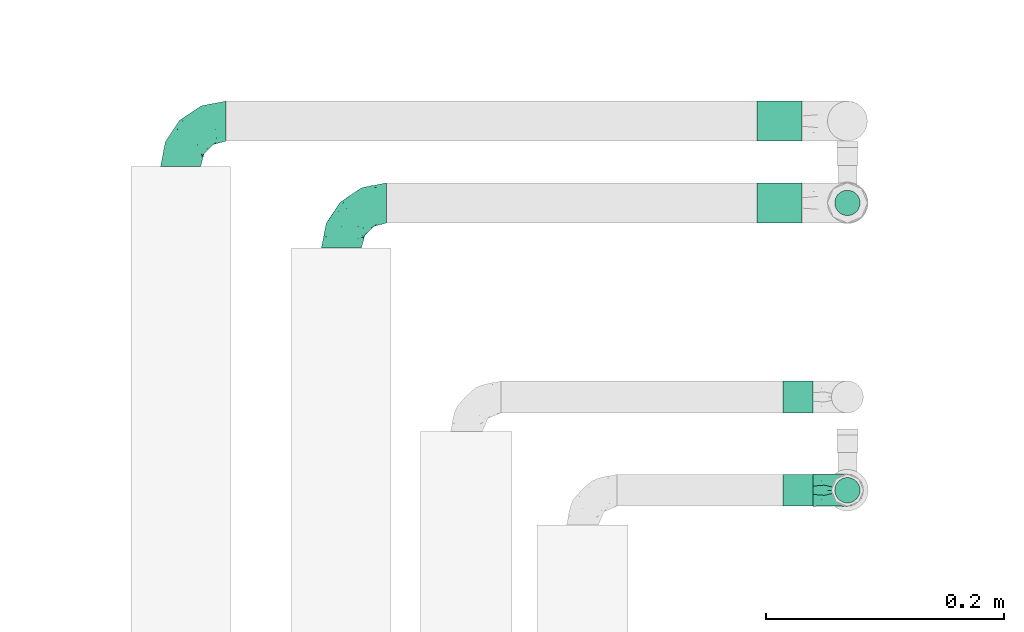
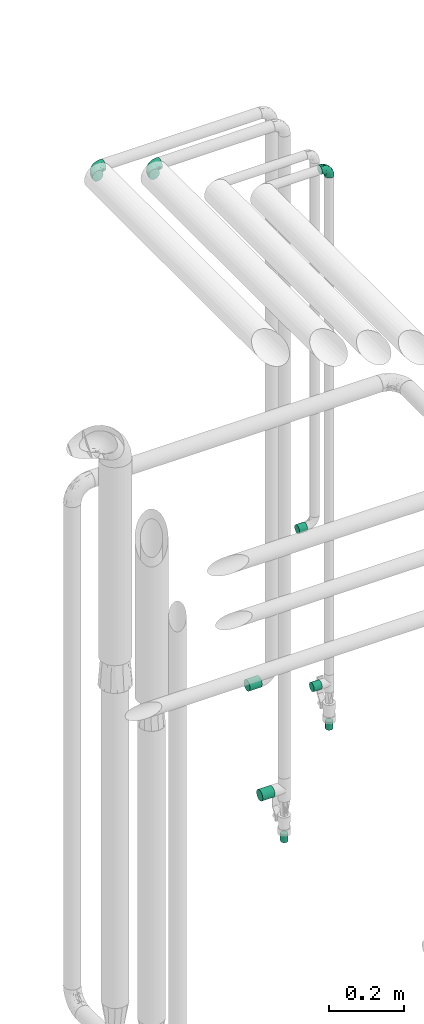
# One storey, part 743 of 824: 9 flow fittings.
"""IFC2X3 building model written with IfcOpenShell, lengths in millimetres."""

from ifc_helpers import new_model, entity, si_unit, converted_unit, derived_unit, direction, frame, origin, origin_2d_with_axis, place, context, subcontext, project, spatial, circle, extrude, faceted_brep, source, transform, mapped, material, type_object, type_shapes, element, save


model = new_model("IFC2X3")

# Units and contexts
model_context = context("Model", 3, precision=0.01, world=origin(), true_north=direction((6.12303176911189e-17, 1.0)))
body_context = subcontext(model_context, "Body", "Model", "MODEL_VIEW")
ifc_project = project(units=[si_unit("LENGTHUNIT", "METRE", prefix="MILLI"), si_unit("AREAUNIT", "SQUARE_METRE"), si_unit("VOLUMEUNIT", "CUBIC_METRE"), converted_unit("PLANEANGLEUNIT", "DEGREE", entity("IfcRatioMeasure", 0.0174532925199433), si_unit("PLANEANGLEUNIT", "RADIAN"), dimensions=[0, 0, 0, 0, 0, 0, 0]), si_unit("MASSUNIT", "GRAM", prefix="KILO"), derived_unit("MASSDENSITYUNIT", [(si_unit("MASSUNIT", "GRAM", prefix="KILO"), 1), (si_unit("LENGTHUNIT", "METRE"), -3)]), derived_unit("MOMENTOFINERTIAUNIT", [(si_unit("LENGTHUNIT", "METRE"), 4)]), si_unit("TIMEUNIT", "SECOND"), si_unit("FREQUENCYUNIT", "HERTZ"), si_unit("THERMODYNAMICTEMPERATUREUNIT", "DEGREE_CELSIUS"), derived_unit("THERMALTRANSMITTANCEUNIT", [(si_unit("MASSUNIT", "GRAM", prefix="KILO"), 1), (si_unit("THERMODYNAMICTEMPERATUREUNIT", "KELVIN"), -1), (si_unit("TIMEUNIT", "SECOND"), -3)]), derived_unit("VOLUMETRICFLOWRATEUNIT", [(si_unit("LENGTHUNIT", "METRE"), 3), (si_unit("TIMEUNIT", "SECOND"), -1)]), derived_unit("MASSFLOWRATEUNIT", [(si_unit("MASSUNIT", "GRAM", prefix="KILO"), 1), (si_unit("TIMEUNIT", "SECOND"), -1)]), derived_unit("ROTATIONALFREQUENCYUNIT", [(si_unit("TIMEUNIT", "SECOND"), -1)]), si_unit("ELECTRICCURRENTUNIT", "AMPERE"), si_unit("ELECTRICVOLTAGEUNIT", "VOLT"), si_unit("POWERUNIT", "WATT"), si_unit("FORCEUNIT", "NEWTON", prefix="KILO"), si_unit("ILLUMINANCEUNIT", "LUX"), si_unit("LUMINOUSFLUXUNIT", "LUMEN"), si_unit("LUMINOUSINTENSITYUNIT", "CANDELA"), derived_unit("USERDEFINED", [(si_unit("MASSUNIT", "GRAM", prefix="KILO"), -1), (si_unit("LENGTHUNIT", "METRE"), -2), (si_unit("TIMEUNIT", "SECOND"), 3), (si_unit("LUMINOUSFLUXUNIT", "LUMEN"), 1)]), derived_unit("LINEARVELOCITYUNIT", [(si_unit("LENGTHUNIT", "METRE"), 1), (si_unit("TIMEUNIT", "SECOND"), -1)]), si_unit("PRESSUREUNIT", "PASCAL"), derived_unit("USERDEFINED", [(si_unit("LENGTHUNIT", "METRE"), -2), (si_unit("MASSUNIT", "GRAM", prefix="KILO"), 1), (si_unit("TIMEUNIT", "SECOND"), -2)]), derived_unit("LINEARFORCEUNIT", [(si_unit("MASSUNIT", "GRAM", prefix="KILO"), 1), (si_unit("LENGTHUNIT", "METRE"), 1), (si_unit("TIMEUNIT", "SECOND"), -2), (si_unit("LENGTHUNIT", "METRE"), -1)]), derived_unit("PLANARFORCEUNIT", [(si_unit("MASSUNIT", "GRAM", prefix="KILO"), 1), (si_unit("LENGTHUNIT", "METRE"), 1), (si_unit("TIMEUNIT", "SECOND"), -2), (si_unit("LENGTHUNIT", "METRE"), -2)])], contexts=[model_context])

# Site, building, storey
site_placement = place(None, origin())
site = spatial("IfcSite", under=ifc_project, at=site_placement, CompositionType="ELEMENT")
building_placement = place(site_placement, origin())
building = spatial("IfcBuilding", under=site, at=building_placement, CompositionType="ELEMENT")
storey_placement = place(building_placement, frame((0.0, 0.0, 28200.0)))
storey = spatial("IfcBuildingStorey", under=building, at=storey_placement, CompositionType="ELEMENT", Elevation=28200.0)

# Flow fittings
ifc_material = material()
pipe_fitting_type_1 = type_object("IfcPipeFittingType", PredefinedType="NOTDEFINED", material=ifc_material)
shared_shape_1 = source(origin(), body_context, "Body", "SweptSolid", [
    extrude(circle(Radius=16.85, at=origin_2d_with_axis()), frame((0.0, 0.0, 0.0), z_axis=(1.0, 0.0, 0.0), x_axis=(0.0, 1.0, 0.0)), (0.0, 0.0, 1.0), 38.0000000000003),
])
type_shapes(pipe_fitting_type_1, [shared_shape_1])
for number, where, z_axis, x_axis in (
    (1, (18867.55, 16586.6, 738.03), (0.0, 1.0, 0.0), (-1.0, 0.0, 0.0)),
    (2, (18867.55, 16517.91, 419.5), (0.0, 1.0, 0.0), (-1.0, 0.0, 0.0)),
):
    element("IfcFlowFitting", number, at=place(storey_placement, frame(where, z_axis=z_axis, x_axis=x_axis)), inside=storey, type_object=pipe_fitting_type_1, material=ifc_material, context=body_context, shape_type="MappedRepresentation", body=[
        mapped(shared_shape_1, transform((0.0, 0.0, 0.0), scale=1.0)),
    ])
pipe_fitting_type_2 = type_object("IfcPipeFittingType", PredefinedType="NOTDEFINED", material=ifc_material)
shared_shape_2 = source(origin(), body_context, "Body", "SweptSolid", [
    extrude(circle(Radius=10.65, at=origin_2d_with_axis()), frame((0.0, 0.0, 0.0), z_axis=(1.0, 0.0, 0.0), x_axis=(0.0, 1.0, 0.0)), (0.0, 0.0, 1.0), 25.0000000000003),
])
type_shapes(pipe_fitting_type_2, [shared_shape_2])
for number, where, z_axis, x_axis in (
    (3, (18905.55, 16517.91, 269.5), (0.0, 1.0, 0.0), (0.0, 0.0, -1.0)),
    (4, (18905.55, 16276.57, 784.61), (0.0, 1.0, 0.0), (0.0, 0.0, -1.0)),
):
    element("IfcFlowFitting", number, at=place(storey_placement, frame(where, z_axis=z_axis, x_axis=x_axis)), inside=storey, type_object=pipe_fitting_type_2, material=ifc_material, context=body_context, shape_type="MappedRepresentation", body=[
        mapped(shared_shape_2, transform((0.0, 0.0, 0.0), scale=1.0)),
    ])
pipe_fitting_type_3 = type_object("IfcPipeFittingType", PredefinedType="NOTDEFINED", material=ifc_material)
shared_shape_3 = source(origin(), body_context, "Body", "SweptSolid", [
    extrude(circle(Radius=13.45, at=origin_2d_with_axis()), frame((0.0, 0.0, 0.0), z_axis=(1.0, 0.0, 0.0), x_axis=(0.0, 1.0, 0.0)), (0.0, 0.0, 1.0), 25.0000000000003),
])
type_shapes(pipe_fitting_type_3, [shared_shape_3])
for number, where, z_axis, x_axis in (
    (5, (18876.45, 16354.91, 1382.4), (0.0, 1.0, 0.0), (-1.0, 0.0, 0.0)),
    (6, (18876.55, 16276.57, 912.61), (0.0, 1.0, 0.0), (-1.0, 0.0, 0.0)),
):
    element("IfcFlowFitting", number, at=place(storey_placement, frame(where, z_axis=z_axis, x_axis=x_axis)), inside=storey, type_object=pipe_fitting_type_3, material=ifc_material, context=body_context, shape_type="MappedRepresentation", body=[
        mapped(shared_shape_3, transform((0.0, 0.0, 0.0), scale=1.0)),
    ])
pipe_fitting_type_4 = type_object("IfcPipeFittingType", PredefinedType="NOTDEFINED", material=ifc_material)
shared_shape_4 = source(origin(), body_context, "Body", "Brep", [
    faceted_brep([(-38.0, 0.0, -16.85), (-38.0, -4.36, -16.28), (-38.0, -8.43, -14.59), (-38.0, -11.91, -11.91), (-38.0, -14.59, -8.43), (-38.0, -16.28, -4.36), (-38.0, -16.85, 0.0), (-38.0, -16.28, 4.36), (-38.0, -14.59, 8.42), (-38.0, -11.91, 11.91), (-38.0, -8.43, 14.59), (-38.0, -4.36, 16.28), (-38.0, 0.0, 16.85), (-38.0, 4.36, 16.28), (-38.0, 8.42, 14.59), (-38.0, 11.91, 11.91), (-38.0, 14.59, 8.42), (-38.0, 16.28, 4.36), (-38.0, 16.85, 0.0), (-38.0, 16.28, -4.36), (-38.0, 14.59, -8.43), (-38.0, 11.91, -11.91), (-38.0, 8.42, -14.59), (-38.0, 4.36, -16.28), (-4.36, 38.0, -16.28), (-8.42, 38.0, -14.59), (-11.91, 38.0, -11.91), (-14.59, 38.0, -8.43), (-16.28, 38.0, -4.36), (-16.85, 38.0, 0.0), (-16.28, 38.0, 4.36), (-14.59, 38.0, 8.42), (-11.91, 38.0, 11.91), (-8.42, 38.0, 14.59), (-4.36, 38.0, 16.28), (0.0, 38.0, 16.85), (4.36, 38.0, 16.28), (8.43, 38.0, 14.59), (11.91, 38.0, 11.91), (14.59, 38.0, 8.42), (16.28, 38.0, 4.36), (16.85, 38.0, 0.0), (16.28, 38.0, -4.36), (14.59, 38.0, -8.43), (11.91, 38.0, -11.91), (8.43, 38.0, -14.59), (4.36, 38.0, -16.28), (0.0, 38.0, -16.85), (-27.9, -12.9, 9.54), (-27.5, -14.76, 0.0), (-16.53, -9.86, 8.66), (-24.93, -9.38, 12.63), (-29.29, -2.05, 16.58), (-26.82, 2.86, 16.81), (-25.18, -14.43, 5.37), (-4.54, 4.54, 14.04), (-15.36, -3.29, 14.19), (-7.56, -2.74, 10.9), (-28.06, -6.15, 15.21), (9.38, 24.93, 12.63), (-4.71, -4.42, 5.51), (-14.62, -10.99, 4.34), (-8.11, -6.73, 0.0), (-19.46, 0.42, 16.39), (-29.52, 14.25, 10.97), (-26.45, 18.14, 7.62), (-32.84, 15.94, 6.96), (-23.39, 16.22, 12.05), (-11.89, 8.53, 16.79), (-5.59, 13.42, 16.64), (-6.64, 18.62, 16.81), (-32.37, 10.35, 13.72), (-6.4, 32.67, 15.76), (-2.55, 28.48, 16.8), (6.81, 15.56, 11.71), (3.29, 15.36, 14.19), (-29.89, 18.0, 3.79), (-29.34, 6.81, 15.88), (-10.26, 4.27, 15.87), (-2.97, 11.0, 15.66), (2.45, 6.84, 10.65), (-1.8, -0.14, 8.44), (5.0, 5.5, 5.57), (-17.68, 27.4, 7.52), (14.43, 25.18, 5.37), (12.9, 27.9, 9.54), (9.86, 16.53, 8.66), (6.15, 28.06, 15.21), (-17.01, -12.67, 0.0), (2.05, 29.29, 16.58), (14.76, 27.5, 0.0), (10.99, 14.62, 4.34), (12.67, 17.01, 0.0), (-15.84, -6.82, 11.83), (-7.71, 25.61, 16.01), (-22.69, 22.69, 4.1), (-19.68, 27.42, 0.0), (-27.42, 19.68, 0.0), (-18.11, 29.67, 3.72), (-10.87, 29.33, 13.9), (-20.83, 21.64, 8.95), (-18.54, 20.86, 11.76), (-14.08, 30.19, 10.92), (-13.69, 20.27, 14.88), (-20.85, 7.92, 16.51), (-19.04, 4.79, 16.85), (-19.82, 12.26, 15.55), (-19.27, 16.43, 13.96), (-10.72, 19.56, 16.07), (-0.42, 19.46, 16.39), (-25.32, 12.08, 14.15), (-9.04, -6.0, 8.28), (-13.94, 13.94, 16.38), (0.78, -0.78, 0.0), (6.73, 8.11, 0.0), (-9.04, -6.0, -8.28), (-15.9, -7.04, -11.65), (-7.56, -2.74, -10.9), (6.15, 28.06, -15.21), (3.29, 15.36, -14.19), (-0.42, 19.46, -16.39), (-30.19, 14.08, -10.92), (-29.33, 10.87, -13.9), (-25.61, 7.71, -16.01), (-32.67, 6.4, -15.76), (-29.67, 18.11, -3.72), (-18.14, 26.45, -7.62), (-22.69, 22.69, -4.1), (-18.0, 29.89, -3.79), (-25.18, -14.43, -5.37), (-14.62, -10.99, -4.34), (-20.27, 13.69, -14.88), (-15.36, -3.29, -14.19), (-14.25, 29.52, -10.97), (-15.94, 32.84, -6.96), (-24.93, -9.38, -12.63), (-27.9, -12.9, -9.54), (6.81, 15.56, -11.71), (9.38, 24.93, -12.63), (-7.92, 20.85, -16.51), (-4.79, 19.04, -16.85), (-8.53, 11.89, -16.79), (-29.29, -2.05, -16.58), (-13.42, 5.59, -16.64), (-4.27, 10.26, -15.87), (-11.0, 2.97, -15.66), (-16.53, -9.86, -8.66), (-28.48, 2.55, -16.8), (-18.62, 6.64, -16.81), (10.99, 14.62, -4.34), (14.43, 25.18, -5.37), (-12.26, 19.82, -15.55), (-16.43, 19.27, -13.96), (12.9, 27.9, -9.54), (-10.35, 32.37, -13.72), (-6.81, 29.34, -15.88), (2.05, 29.29, -16.58), (-2.86, 26.82, -16.81), (-27.4, 17.68, -7.52), (5.0, 5.5, -5.57), (-16.22, 23.39, -12.05), (-28.06, -6.15, -15.21), (9.86, 16.53, -8.66), (-20.86, 18.54, -11.76), (-21.64, 20.83, -8.95), (-19.56, 10.72, -16.07), (-19.46, 0.42, -16.39), (-12.08, 25.32, -14.15), (-4.54, 4.54, -14.04), (-13.94, 13.94, -16.38), (2.45, 6.84, -10.65), (-4.71, -4.42, -5.51), (-1.8, -0.14, -8.44)], [[[0, 1, 2, 3, 4, 5, 6, 7, 8, 9, 10, 11, 12, 13, 14, 15, 16, 17, 18, 19, 20, 21, 22, 23]], [[24, 25, 26, 27, 28, 29, 30, 31, 32, 33, 34, 35, 36, 37, 38, 39, 40, 41, 42, 43, 44, 45, 46, 47]], [[8, 48, 9]], [[7, 6, 49]], [[48, 50, 51]], [[12, 52, 53]], [[8, 54, 48]], [[7, 54, 8]], [[55, 56, 57]], [[51, 10, 9]], [[51, 58, 10]], [[59, 38, 37]], [[60, 61, 62]], [[58, 56, 63]], [[64, 65, 66]], [[67, 65, 64]], [[68, 69, 70]], [[14, 71, 15]], [[11, 52, 12]], [[34, 72, 73]], [[12, 53, 13]], [[15, 64, 16]], [[74, 59, 75]], [[18, 17, 76]], [[66, 17, 16]], [[77, 13, 53]], [[13, 77, 14]], [[69, 78, 79]], [[80, 81, 82]], [[31, 30, 83]], [[84, 85, 86]], [[59, 87, 75]], [[61, 54, 88]], [[35, 89, 36]], [[84, 40, 39]], [[35, 34, 73]], [[90, 40, 84]], [[39, 38, 85]], [[10, 58, 11]], [[85, 84, 39]], [[91, 84, 86]], [[84, 92, 90]], [[87, 37, 36]], [[93, 56, 51]], [[94, 70, 73]], [[95, 96, 97]], [[84, 91, 92]], [[96, 98, 29]], [[33, 32, 99]], [[76, 95, 97]], [[100, 101, 83]], [[102, 99, 32]], [[65, 95, 76]], [[103, 94, 99]], [[95, 98, 96]], [[72, 99, 94]], [[72, 34, 33]], [[101, 99, 102]], [[7, 49, 54]], [[87, 59, 37]], [[104, 105, 68]], [[106, 103, 107]], [[106, 77, 104]], [[32, 31, 102]], [[94, 103, 108]], [[94, 108, 70]], [[89, 73, 109]], [[71, 64, 15]], [[110, 107, 67]], [[50, 48, 54]], [[51, 9, 48]], [[56, 58, 51]], [[88, 54, 49]], [[52, 58, 63]], [[50, 111, 93]], [[56, 55, 78]], [[38, 59, 85]], [[86, 85, 59]], [[89, 87, 36]], [[41, 40, 90]], [[109, 79, 75]], [[109, 75, 87]], [[75, 55, 80]], [[104, 77, 53]], [[71, 77, 110]], [[31, 83, 102]], [[101, 102, 83]], [[99, 101, 103]], [[106, 107, 110]], [[68, 70, 112]], [[109, 73, 70]], [[68, 112, 104]], [[68, 63, 78]], [[57, 93, 111]], [[80, 55, 57]], [[61, 50, 54]], [[80, 82, 86]], [[81, 57, 111]], [[74, 86, 59]], [[60, 113, 82]], [[82, 114, 91]], [[100, 95, 65]], [[98, 95, 83]], [[73, 89, 35]], [[87, 89, 109]], [[58, 52, 11]], [[53, 52, 63]], [[104, 53, 105]], [[106, 104, 112]], [[18, 76, 97]], [[76, 17, 66]], [[103, 106, 112]], [[77, 106, 110]], [[103, 101, 107]], [[67, 107, 101]], [[67, 101, 100]], [[110, 67, 64]], [[83, 30, 98]], [[29, 98, 30]], [[53, 63, 105]], [[63, 68, 105]], [[56, 78, 63]], [[79, 78, 55]], [[75, 79, 55]], [[69, 79, 109]], [[70, 69, 109]], [[78, 69, 68]], [[62, 113, 60]], [[111, 61, 60]], [[61, 88, 62]], [[86, 82, 91]], [[77, 71, 14]], [[114, 82, 113]], [[114, 92, 91]], [[64, 71, 110]], [[99, 72, 33]], [[73, 72, 94]], [[64, 66, 16]], [[76, 66, 65]], [[95, 100, 83]], [[67, 100, 65]], [[75, 80, 74]], [[80, 86, 74]], [[103, 112, 108]], [[70, 108, 112]], [[50, 93, 51]], [[57, 56, 93]], [[61, 111, 50]], [[81, 111, 60]], [[82, 81, 60]], [[80, 57, 81]], [[115, 116, 117]], [[118, 119, 120]], [[121, 122, 21]], [[123, 124, 122]], [[97, 125, 18]], [[126, 127, 128]], [[127, 97, 96]], [[129, 130, 88]], [[123, 122, 131]], [[116, 132, 117]], [[133, 126, 134]], [[22, 124, 23]], [[3, 135, 136]], [[137, 119, 138]], [[129, 88, 49]], [[139, 140, 141]], [[4, 3, 136]], [[45, 118, 46]], [[142, 1, 0]], [[143, 144, 145]], [[4, 129, 5]], [[129, 136, 146]], [[147, 0, 23]], [[22, 21, 122]], [[127, 125, 97]], [[123, 148, 147]], [[96, 128, 127]], [[149, 150, 92]], [[29, 28, 128]], [[151, 131, 152]], [[26, 133, 27]], [[153, 44, 43]], [[135, 3, 2]], [[26, 25, 154]], [[155, 25, 24]], [[47, 156, 157]], [[47, 46, 156]], [[20, 19, 158]], [[159, 149, 114]], [[126, 133, 160]], [[141, 143, 148]], [[45, 138, 118]], [[161, 135, 2]], [[155, 24, 157]], [[23, 124, 147]], [[115, 146, 116]], [[44, 153, 138]], [[138, 45, 44]], [[153, 162, 138]], [[161, 2, 1]], [[41, 90, 42]], [[130, 129, 146]], [[49, 5, 129]], [[42, 150, 43]], [[163, 122, 121]], [[47, 157, 24]], [[135, 161, 132]], [[134, 28, 27]], [[42, 90, 150]], [[164, 163, 158]], [[151, 155, 139]], [[21, 20, 121]], [[123, 131, 165]], [[123, 165, 148]], [[142, 147, 166]], [[154, 133, 26]], [[167, 152, 160]], [[146, 136, 135]], [[6, 5, 49]], [[129, 4, 136]], [[142, 161, 1]], [[166, 145, 132]], [[166, 132, 161]], [[132, 168, 117]], [[43, 150, 153]], [[92, 150, 90]], [[162, 153, 150]], [[119, 118, 138]], [[156, 118, 120]], [[137, 138, 162]], [[119, 168, 144]], [[139, 155, 157]], [[154, 155, 167]], [[20, 158, 121]], [[163, 121, 158]], [[122, 163, 131]], [[151, 152, 167]], [[141, 148, 169]], [[166, 147, 148]], [[141, 169, 139]], [[141, 120, 144]], [[168, 170, 117]], [[159, 171, 172]], [[115, 172, 171]], [[171, 62, 130]], [[119, 170, 168]], [[170, 162, 159]], [[149, 162, 150]], [[113, 171, 159]], [[164, 127, 126]], [[125, 127, 158]], [[147, 142, 0]], [[161, 142, 166]], [[118, 156, 46]], [[157, 156, 120]], [[139, 157, 140]], [[151, 139, 169]], [[29, 128, 96]], [[128, 28, 134]], [[131, 151, 169]], [[155, 151, 167]], [[131, 163, 152]], [[160, 152, 163]], [[160, 163, 164]], [[167, 160, 133]], [[158, 19, 125]], [[18, 125, 19]], [[157, 120, 140]], [[120, 141, 140]], [[119, 144, 120]], [[145, 144, 168]], [[132, 145, 168]], [[143, 145, 166]], [[148, 143, 166]], [[144, 143, 141]], [[115, 130, 146]], [[114, 113, 159]], [[62, 171, 113]], [[62, 88, 130]], [[159, 162, 149]], [[149, 92, 114]], [[155, 154, 25]], [[133, 154, 167]], [[122, 124, 22]], [[147, 124, 123]], [[133, 134, 27]], [[128, 134, 126]], [[127, 164, 158]], [[160, 164, 126]], [[162, 170, 137]], [[170, 119, 137]], [[131, 169, 165]], [[148, 165, 169]], [[146, 135, 116]], [[132, 116, 135]], [[172, 115, 117]], [[130, 115, 171]], [[117, 170, 172]], [[159, 172, 170]]]),
])
type_shapes(pipe_fitting_type_4, [shared_shape_4])
for number, where, z_axis, x_axis in (
    (7, (18480.55, 16517.91, 2600.0), (0.0, 0.0, 1.0), (-1.0, 0.0, 0.0)),
    (8, (18345.55, 16586.6, 2600.0), (0.0, 0.0, 1.0), (-1.0, 0.0, 0.0)),
):
    element("IfcFlowFitting", number, at=place(storey_placement, frame(where, z_axis=z_axis, x_axis=x_axis)), inside=storey, type_object=pipe_fitting_type_4, material=ifc_material, context=body_context, shape_type="MappedRepresentation", body=[
        mapped(shared_shape_4, transform((0.0, 0.0, 0.0), scale=1.0)),
    ])
pipe_fitting_type_5 = type_object("IfcPipeFittingType", PredefinedType="NOTDEFINED", material=ifc_material)
shared_shape_5 = source(origin(), body_context, "Body", "Brep", [
    faceted_brep([(-29.1, 0.0, -13.45), (-29.1, -3.48, -12.99), (-29.1, -6.73, -11.65), (-29.1, -9.51, -9.51), (-29.1, -11.65, -6.73), (-29.1, -12.99, -3.48), (-29.1, -13.45, 0.0), (-29.1, -12.99, 3.48), (-29.1, -11.65, 6.72), (-29.1, -9.51, 9.51), (-29.1, -6.73, 11.65), (-29.1, -3.48, 12.99), (-29.1, 0.0, 13.45), (-29.1, 3.48, 12.99), (-29.1, 6.72, 11.65), (-29.1, 9.51, 9.51), (-29.1, 11.65, 6.72), (-29.1, 12.99, 3.48), (-29.1, 13.45, 0.0), (-29.1, 12.99, -3.48), (-29.1, 11.65, -6.73), (-29.1, 9.51, -9.51), (-29.1, 6.72, -11.65), (-29.1, 3.48, -12.99), (-3.48, 29.1, -12.99), (-6.72, 29.1, -11.65), (-9.51, 29.1, -9.51), (-11.65, 29.1, -6.73), (-12.99, 29.1, -3.48), (-13.45, 29.1, 0.0), (-12.99, 29.1, 3.48), (-11.65, 29.1, 6.72), (-9.51, 29.1, 9.51), (-6.72, 29.1, 11.65), (-3.48, 29.1, 12.99), (0.0, 29.1, 13.45), (3.48, 29.1, 12.99), (6.73, 29.1, 11.65), (9.51, 29.1, 9.51), (11.65, 29.1, 6.72), (12.99, 29.1, 3.48), (13.45, 29.1, 0.0), (12.99, 29.1, -3.48), (11.65, 29.1, -6.73), (9.51, 29.1, -9.51), (6.73, 29.1, -11.65), (3.48, 29.1, -12.99), (0.0, 29.1, -13.45), (-19.62, -11.66, 4.28), (-21.41, -10.36, 7.6), (-16.26, -10.01, 0.0), (-12.48, -9.76, 2.75), (-10.66, 15.6, 11.91), (-15.27, 9.55, 12.42), (-10.71, 10.71, 13.09), (-0.04, 0.04, 0.0), (0.49, -0.45, 4.38), (-3.67, -4.15, 4.26), (-22.68, -11.73, 0.0), (-21.45, -4.97, 12.13), (-11.59, -2.84, 11.28), (-14.77, 0.17, 13.07), (-19.08, -7.58, 10.06), (-22.36, -1.69, 13.23), (-20.49, 2.21, 13.42), (-7.82, -7.75, 0.0), (-5.53, -2.55, 8.58), (-1.33, -0.87, 6.53), (-1.15, 1.15, 8.49), (-22.46, 5.38, 12.69), (-14.04, 21.05, 6.04), (-3.19, 3.19, 11.14), (-5.08, 25.05, 12.59), (-1.97, 21.79, 13.41), (-22.68, 11.31, 8.78), (-18.16, 12.64, 9.68), (-20.46, 14.33, 6.11), (-4.13, 10.11, 13.26), (-7.66, 3.08, 12.63), (-2.02, 8.24, 12.45), (-24.91, 8.22, 10.95), (-5.08, 14.28, 13.42), (-8.96, 6.48, 13.4), (-19.7, 16.14, 3.1), (-18.03, 18.03, 0.0), (-23.05, 15.96, 0.0), (-25.26, 12.69, 5.56), (4.97, 21.45, 12.13), (7.58, 19.08, 10.06), (1.69, 22.36, 13.23), (10.36, 21.41, 7.6), (8.11, 12.69, 6.86), (11.66, 19.62, 4.28), (-6.03, 19.65, 12.79), (9.76, 12.48, 2.75), (10.01, 16.26, 0.0), (-14.58, 16.06, 9.44), (-11.19, 23.14, 8.74), (-16.29, 16.8, 7.24), (-11.99, -5.68, 9.36), (-15.42, 20.78, 3.08), (5.79, 12.02, 9.27), (2.84, 11.59, 11.28), (2.55, 5.53, 8.58), (-15.74, 23.57, 0.0), (-15.96, 23.05, 0.0), (-24.62, 13.88, 2.39), (-8.61, 22.49, 11.12), (-14.98, 12.8, 11.14), (11.73, 22.68, 0.0), (-12.69, -8.11, 6.86), (7.75, 7.82, 0.0), (-15.98, 6.12, 13.19), (-14.48, 3.64, 13.45), (-19.6, 9.46, 11.31), (-8.3, 15.02, 12.85), (-0.17, 14.77, 13.07), (-6.9, -5.2, 6.52), (7.5, 8.93, 4.46), (5.22, 6.95, 6.56), (-8.85, -7.47, 4.42), (3.86, 3.93, 0.0), (4.18, 3.75, 4.31), (-23.57, 15.74, 0.0), (-3.93, -3.86, 0.0), (-21.79, 1.97, -13.41), (-11.31, 22.68, -8.78), (-14.33, 20.46, -6.11), (-12.69, 25.26, -5.56), (4.97, 21.45, -12.13), (2.84, 11.59, -11.28), (-0.17, 14.77, -13.07), (-25.05, 5.08, -12.59), (-16.8, 16.29, -7.24), (-20.78, 15.42, -3.08), (-16.14, 19.7, -3.1), (-12.02, -5.79, -9.27), (-11.59, -2.84, -11.28), (-5.53, -2.55, -8.58), (-23.14, 11.19, -8.74), (-22.49, 8.61, -11.12), (-1.33, -0.87, -6.53), (-3.67, -4.15, -4.26), (-6.9, -5.2, -6.52), (-19.65, 6.03, -12.79), (-15.6, 10.66, -11.91), (-14.28, 5.08, -13.42), (-10.71, 10.71, -13.09), (-6.48, 8.96, -13.4), (-19.62, -11.66, -4.28), (-21.41, -10.36, -7.6), (-12.48, -9.76, -2.75), (11.66, 19.62, -4.28), (-12.69, -8.11, -6.86), (-22.36, -1.69, -13.23), (-16.06, 14.58, -9.44), (5.68, 11.99, -9.36), (7.58, 19.08, -10.06), (-19.08, -7.58, -10.06), (-21.45, -4.97, -12.13), (-9.55, 15.27, -12.42), (-12.8, 14.98, -11.14), (-8.22, 24.91, -10.95), (10.36, 21.41, -7.6), (-5.38, 22.46, -12.69), (1.69, 22.36, -13.23), (-2.21, 20.49, -13.42), (-12.64, 18.16, -9.68), (-21.05, 14.04, -6.04), (9.76, 12.48, -2.75), (-10.11, 4.13, -13.26), (-3.08, 7.66, -12.63), (-8.24, 2.02, -12.45), (-13.88, 24.62, -2.39), (8.11, 12.69, -6.86), (-6.12, 15.98, -13.19), (-3.64, 14.48, -13.45), (-9.46, 19.6, -11.31), (-15.02, 8.3, -12.85), (-14.77, 0.17, -13.07), (-3.19, 3.19, -11.14), (5.22, 6.95, -6.56), (2.55, 5.53, -8.58), (0.49, -0.45, -4.38), (4.18, 3.75, -4.31), (-8.85, -7.47, -4.42), (-1.15, 1.15, -8.49), (7.5, 8.93, -4.46)], [[[0, 1, 2, 3, 4, 5, 6, 7, 8, 9, 10, 11, 12, 13, 14, 15, 16, 17, 18, 19, 20, 21, 22, 23]], [[24, 25, 26, 27, 28, 29, 30, 31, 32, 33, 34, 35, 36, 37, 38, 39, 40, 41, 42, 43, 44, 45, 46, 47]], [[48, 49, 8]], [[48, 50, 51]], [[52, 53, 54]], [[55, 56, 57]], [[49, 9, 8]], [[58, 48, 7]], [[59, 60, 61]], [[62, 10, 9]], [[62, 59, 10]], [[12, 63, 64]], [[51, 50, 65]], [[66, 67, 68]], [[12, 11, 63]], [[69, 14, 13]], [[31, 30, 70]], [[66, 71, 60]], [[34, 72, 73]], [[74, 75, 76]], [[77, 78, 79]], [[14, 80, 15]], [[16, 15, 74]], [[81, 54, 82]], [[83, 84, 85]], [[74, 76, 86]], [[37, 87, 88]], [[88, 38, 37]], [[36, 35, 89]], [[90, 91, 92]], [[93, 81, 73]], [[35, 34, 73]], [[10, 59, 11]], [[92, 94, 95]], [[96, 97, 98]], [[90, 92, 39]], [[99, 60, 62]], [[40, 39, 92]], [[87, 37, 36]], [[100, 84, 83]], [[50, 48, 58]], [[100, 83, 98]], [[101, 102, 103]], [[104, 105, 84, 100, 29]], [[48, 8, 7]], [[86, 17, 16]], [[106, 18, 17]], [[32, 97, 107]], [[53, 52, 108]], [[52, 93, 107]], [[97, 96, 107]], [[72, 107, 93]], [[72, 34, 33]], [[92, 109, 40]], [[33, 32, 107]], [[69, 13, 64]], [[88, 87, 102]], [[12, 64, 13]], [[49, 110, 62]], [[39, 38, 90]], [[95, 94, 111]], [[112, 113, 82]], [[53, 69, 112]], [[80, 74, 15]], [[114, 108, 75]], [[32, 31, 97]], [[115, 52, 54]], [[93, 115, 81]], [[89, 73, 116]], [[106, 76, 83]], [[106, 83, 85]], [[83, 76, 98]], [[100, 30, 29]], [[60, 59, 62]], [[63, 59, 61]], [[110, 117, 99]], [[60, 71, 78]], [[89, 87, 36]], [[116, 79, 102]], [[116, 102, 87]], [[102, 71, 103]], [[110, 49, 48]], [[62, 9, 49]], [[38, 88, 90]], [[91, 90, 88]], [[112, 69, 64]], [[80, 69, 114]], [[111, 94, 118]], [[119, 101, 103]], [[117, 66, 99]], [[117, 120, 57]], [[119, 91, 101]], [[66, 68, 71]], [[66, 117, 67]], [[121, 111, 122, 55]], [[56, 55, 122]], [[31, 70, 97]], [[97, 70, 98]], [[107, 96, 52]], [[53, 108, 114]], [[112, 82, 54]], [[116, 73, 81]], [[78, 82, 61]], [[81, 82, 77]], [[73, 89, 35]], [[87, 89, 116]], [[59, 63, 11]], [[64, 63, 61]], [[112, 64, 113]], [[53, 112, 54]], [[7, 6, 58]], [[109, 92, 95]], [[109, 41, 40]], [[69, 53, 114]], [[52, 96, 108]], [[75, 108, 96]], [[75, 96, 98]], [[114, 75, 74]], [[64, 61, 113]], [[61, 82, 113]], [[91, 88, 101]], [[110, 48, 51]], [[92, 91, 94]], [[91, 119, 118]], [[106, 85, 123, 18]], [[106, 17, 86]], [[60, 78, 61]], [[79, 78, 71]], [[102, 79, 71]], [[77, 79, 116]], [[81, 77, 116]], [[78, 77, 82]], [[69, 80, 14]], [[74, 80, 114]], [[74, 86, 16]], [[106, 86, 76]], [[107, 72, 33]], [[73, 72, 93]], [[98, 70, 100]], [[75, 98, 76]], [[30, 100, 70]], [[110, 99, 62]], [[66, 60, 99]], [[120, 110, 51]], [[67, 117, 57]], [[57, 56, 67]], [[67, 122, 119]], [[110, 120, 117]], [[65, 120, 51]], [[57, 65, 124, 55]], [[122, 67, 56]], [[67, 103, 68]], [[71, 68, 103]], [[65, 57, 120]], [[102, 101, 88]], [[67, 119, 103]], [[118, 119, 122]], [[118, 122, 111]], [[91, 118, 94]], [[81, 115, 54]], [[93, 52, 115]], [[23, 125, 0]], [[126, 127, 128]], [[129, 130, 131]], [[23, 22, 132]], [[133, 134, 135]], [[136, 137, 138]], [[21, 139, 140]], [[141, 142, 143]], [[144, 140, 145]], [[143, 136, 138]], [[146, 147, 148]], [[144, 132, 140]], [[5, 4, 149]], [[4, 3, 150]], [[45, 129, 46]], [[151, 50, 149]], [[152, 43, 42]], [[42, 41, 109]], [[150, 149, 4]], [[153, 149, 150]], [[154, 1, 0]], [[139, 155, 140]], [[156, 130, 157]], [[149, 58, 5]], [[18, 123, 85, 84, 134]], [[158, 159, 137]], [[84, 105, 135]], [[160, 145, 161]], [[143, 153, 136]], [[27, 26, 126]], [[25, 162, 26]], [[152, 163, 43]], [[25, 24, 164]], [[47, 165, 166]], [[158, 3, 2]], [[167, 127, 126]], [[20, 19, 168]], [[47, 46, 165]], [[44, 157, 45]], [[23, 132, 125]], [[44, 43, 163]], [[158, 2, 159]], [[47, 166, 24]], [[129, 45, 157]], [[164, 24, 166]], [[134, 84, 135]], [[95, 169, 152]], [[22, 21, 140]], [[144, 146, 125]], [[109, 152, 42]], [[95, 152, 109]], [[170, 171, 172]], [[155, 139, 133]], [[28, 27, 128]], [[159, 2, 1]], [[173, 29, 28]], [[50, 151, 65]], [[169, 95, 111]], [[163, 174, 157]], [[175, 176, 148]], [[160, 164, 175]], [[162, 126, 26]], [[177, 161, 167]], [[21, 20, 139]], [[144, 145, 178]], [[144, 178, 146]], [[154, 125, 179]], [[173, 127, 135]], [[173, 135, 105]], [[135, 127, 133]], [[134, 19, 18]], [[154, 159, 1]], [[179, 172, 137]], [[179, 137, 159]], [[137, 180, 138]], [[130, 129, 157]], [[165, 129, 131]], [[174, 181, 156]], [[130, 180, 171]], [[3, 158, 150]], [[153, 150, 158]], [[174, 163, 152]], [[157, 44, 163]], [[175, 164, 166]], [[162, 164, 177]], [[130, 182, 180]], [[181, 141, 182]], [[55, 183, 184]], [[65, 151, 185]], [[183, 55, 142]], [[156, 181, 182]], [[180, 182, 186]], [[181, 187, 184]], [[65, 142, 55, 124]], [[20, 168, 139]], [[139, 168, 133]], [[140, 155, 145]], [[160, 161, 177]], [[175, 148, 147]], [[179, 125, 146]], [[171, 148, 131]], [[146, 148, 170]], [[125, 154, 0]], [[159, 154, 179]], [[129, 165, 46]], [[166, 165, 131]], [[175, 166, 176]], [[160, 175, 147]], [[58, 149, 50]], [[58, 6, 5]], [[145, 160, 147]], [[164, 160, 177]], [[145, 155, 161]], [[167, 161, 155]], [[167, 155, 133]], [[177, 167, 126]], [[166, 131, 176]], [[131, 148, 176]], [[149, 153, 151]], [[153, 143, 185]], [[145, 147, 178]], [[174, 152, 169]], [[173, 105, 104, 29]], [[173, 28, 128]], [[130, 171, 131]], [[172, 171, 180]], [[137, 172, 180]], [[170, 172, 179]], [[146, 170, 179]], [[171, 170, 148]], [[164, 162, 25]], [[126, 162, 177]], [[126, 128, 27]], [[173, 128, 127]], [[140, 132, 22]], [[125, 132, 144]], [[133, 168, 134]], [[167, 133, 127]], [[19, 134, 168]], [[153, 158, 136]], [[137, 136, 158]], [[141, 143, 138]], [[185, 143, 142]], [[186, 141, 138]], [[183, 142, 141]], [[185, 142, 65]], [[153, 185, 151]], [[180, 186, 138]], [[182, 141, 186]], [[141, 184, 183]], [[184, 111, 121, 55]], [[174, 156, 157]], [[182, 130, 156]], [[187, 174, 169]], [[141, 181, 184]], [[174, 187, 181]], [[111, 187, 169]], [[111, 184, 187]], [[146, 178, 147]]]),
])
type_shapes(pipe_fitting_type_5, [shared_shape_5])
flow_fitting_placement = place(storey_placement, frame((18905.55, 16276.57, 2600.0), z_axis=(0.0, 1.0, 0.0), x_axis=(1.0, 0.0, 0.0)))
element("IfcFlowFitting", 9, at=flow_fitting_placement, inside=storey, type_object=pipe_fitting_type_5, material=ifc_material, context=body_context, shape_type="MappedRepresentation", body=[
    mapped(shared_shape_5, transform((0.0, 0.0, 0.0), scale=1.0)),
])

save(model, "model.ifc")
